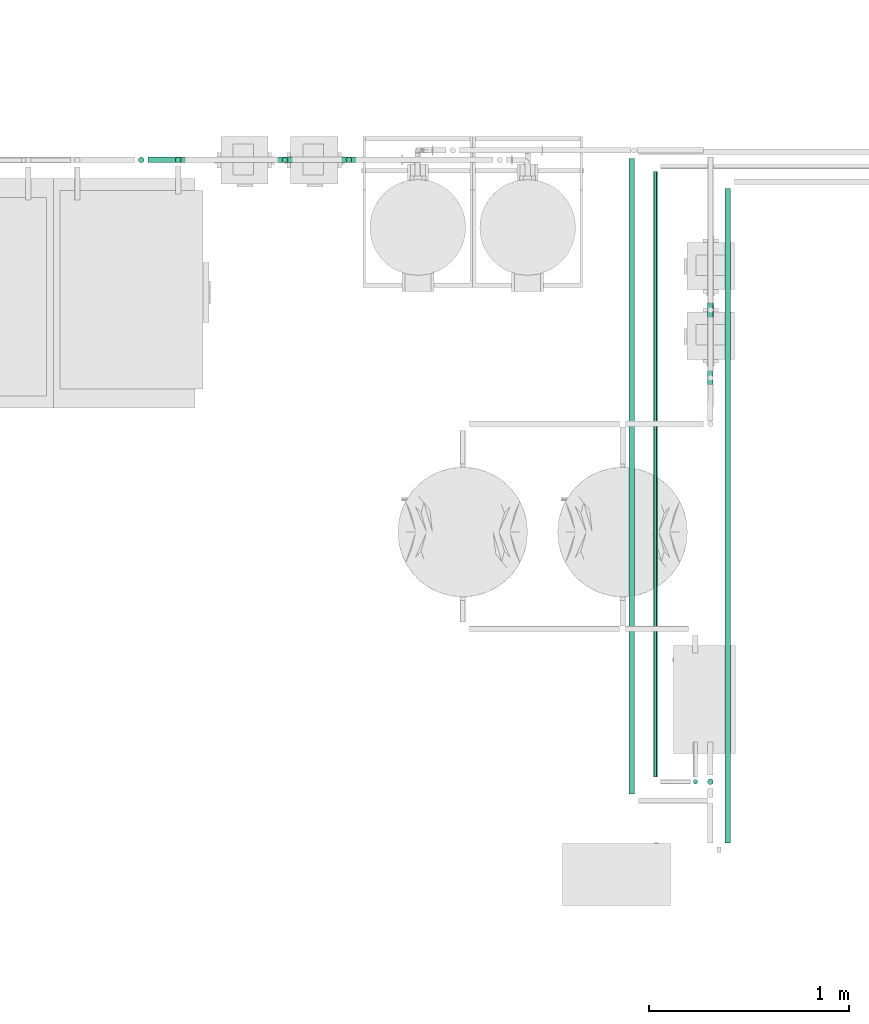
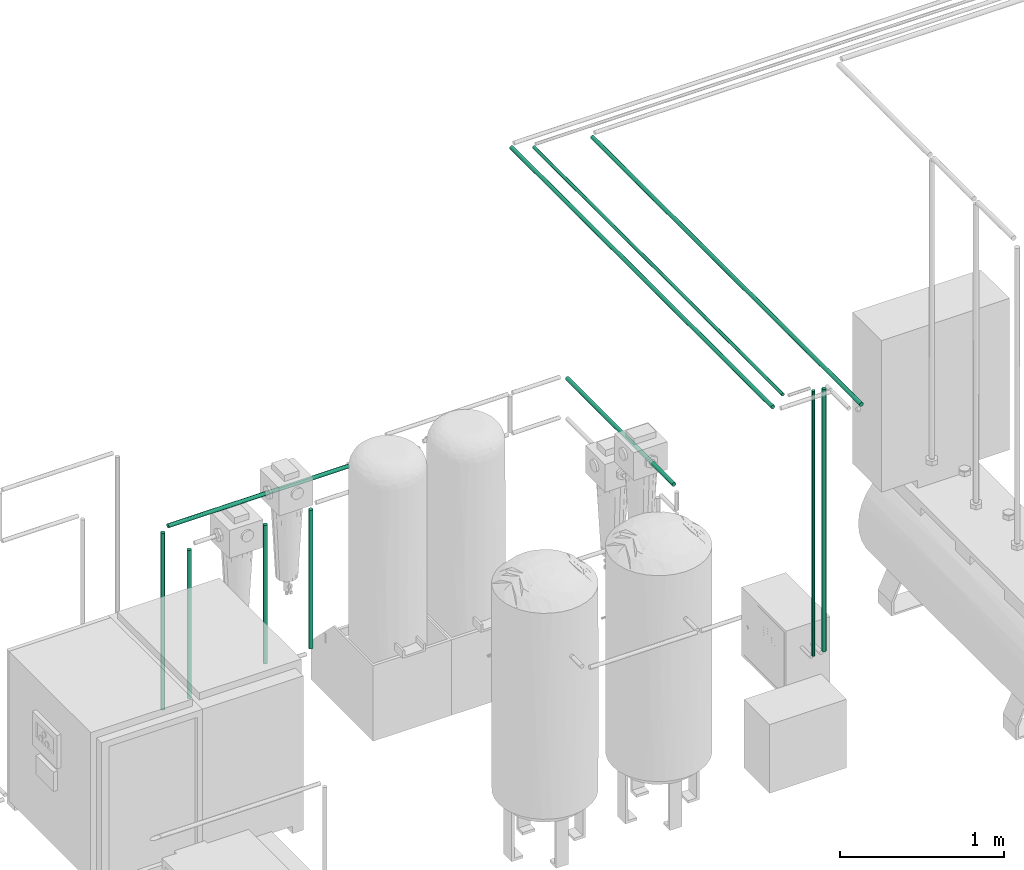
# One storey, part 42 of 331: 11 flow segments.
"""IFC2X3 building model written with IfcOpenShell, lengths in millimetres."""

from ifc_helpers import new_model, entity, si_unit, converted_unit, derived_unit, direction, frame, frame_2d, origin, origin_2d_with_axis, place, context, subcontext, project, spatial, circle, extrude, type_object, element, save


model = new_model("IFC2X3")

# Units and contexts
model_context = context("Model", 3, precision=0.01, world=origin(), true_north=direction((6.12303176911189e-17, 1.0)))
body_context = subcontext(model_context, "Body", "Model", "MODEL_VIEW")
ifc_project = project(units=[si_unit("LENGTHUNIT", "METRE", prefix="MILLI"), si_unit("AREAUNIT", "SQUARE_METRE"), si_unit("VOLUMEUNIT", "CUBIC_METRE"), converted_unit("PLANEANGLEUNIT", "DEGREE", entity("IfcRatioMeasure", 0.0174532925199433), si_unit("PLANEANGLEUNIT", "RADIAN"), dimensions=[0, 0, 0, 0, 0, 0, 0]), si_unit("MASSUNIT", "GRAM", prefix="KILO"), derived_unit("MASSDENSITYUNIT", [(si_unit("MASSUNIT", "GRAM", prefix="KILO"), 1), (si_unit("LENGTHUNIT", "METRE"), -3)]), derived_unit("MOMENTOFINERTIAUNIT", [(si_unit("LENGTHUNIT", "METRE"), 4)]), si_unit("TIMEUNIT", "SECOND"), si_unit("FREQUENCYUNIT", "HERTZ"), si_unit("THERMODYNAMICTEMPERATUREUNIT", "DEGREE_CELSIUS"), derived_unit("THERMALTRANSMITTANCEUNIT", [(si_unit("MASSUNIT", "GRAM", prefix="KILO"), 1), (si_unit("THERMODYNAMICTEMPERATUREUNIT", "KELVIN"), -1), (si_unit("TIMEUNIT", "SECOND"), -3)]), derived_unit("VOLUMETRICFLOWRATEUNIT", [(si_unit("LENGTHUNIT", "METRE"), 3), (si_unit("TIMEUNIT", "SECOND"), -1)]), derived_unit("MASSFLOWRATEUNIT", [(si_unit("MASSUNIT", "GRAM", prefix="KILO"), 1), (si_unit("TIMEUNIT", "SECOND"), -1)]), derived_unit("ROTATIONALFREQUENCYUNIT", [(si_unit("TIMEUNIT", "SECOND"), -1)]), si_unit("ELECTRICCURRENTUNIT", "AMPERE"), si_unit("ELECTRICVOLTAGEUNIT", "VOLT"), si_unit("POWERUNIT", "WATT"), si_unit("FORCEUNIT", "NEWTON", prefix="KILO"), si_unit("ILLUMINANCEUNIT", "LUX"), si_unit("LUMINOUSFLUXUNIT", "LUMEN"), si_unit("LUMINOUSINTENSITYUNIT", "CANDELA"), derived_unit("USERDEFINED", [(si_unit("MASSUNIT", "GRAM", prefix="KILO"), -1), (si_unit("LENGTHUNIT", "METRE"), -2), (si_unit("TIMEUNIT", "SECOND"), 3), (si_unit("LUMINOUSFLUXUNIT", "LUMEN"), 1)]), derived_unit("LINEARVELOCITYUNIT", [(si_unit("LENGTHUNIT", "METRE"), 1), (si_unit("TIMEUNIT", "SECOND"), -1)]), si_unit("PRESSUREUNIT", "PASCAL"), derived_unit("USERDEFINED", [(si_unit("LENGTHUNIT", "METRE"), -2), (si_unit("MASSUNIT", "GRAM", prefix="KILO"), 1), (si_unit("TIMEUNIT", "SECOND"), -2)]), derived_unit("LINEARFORCEUNIT", [(si_unit("MASSUNIT", "GRAM", prefix="KILO"), 1), (si_unit("LENGTHUNIT", "METRE"), 1), (si_unit("TIMEUNIT", "SECOND"), -2), (si_unit("LENGTHUNIT", "METRE"), -1)]), derived_unit("PLANARFORCEUNIT", [(si_unit("MASSUNIT", "GRAM", prefix="KILO"), 1), (si_unit("LENGTHUNIT", "METRE"), 1), (si_unit("TIMEUNIT", "SECOND"), -2), (si_unit("LENGTHUNIT", "METRE"), -2)])], contexts=[model_context])

# Site, building, storey
site_placement = place(None, frame((0.0, -0.00077364408347762, 0.0)))
site = spatial("IfcSite", under=ifc_project, at=site_placement, CompositionType="ELEMENT")
building_placement = place(site_placement, origin())
building = spatial("IfcBuilding", under=site, at=building_placement, CompositionType="ELEMENT")
storey_placement = place(building_placement, origin())
storey = spatial("IfcBuildingStorey", under=building, at=storey_placement, CompositionType="ELEMENT", Elevation=0.0)

# Flow segments
pipe_segment_type = type_object("IfcPipeSegmentType", PredefinedType="NOTDEFINED")
flow_segment_1_placement = place(storey_placement, frame((55259.7935041802, -3861.13012235031, 2834.40472776411)))
element("IfcFlowSegment", 1, at=flow_segment_1_placement, inside=storey, type_object=pipe_segment_type, context=body_context, shape_type="SweptSolid", body=[
    extrude(circle(Radius=14.0, at=origin_2d_with_axis()), frame((15.5952722359127, 0.0, 15.595272235916), z_axis=(0.0, 1.0, 0.0), x_axis=(-1.0, 0.0, 0.0)), (0.0, 0.0, 1.0), 3182.00000000001),
])
flow_segment_2_placement = place(storey_placement, frame((55382.4083446482, -3776.13012235021, 2837.40472776406)))
element("IfcFlowSegment", 2, at=flow_segment_2_placement, inside=storey, type_object=pipe_segment_type, context=body_context, shape_type="SweptSolid", body=[
    extrude(circle(Radius=11.0, at=frame_2d((8.66293703438714e-12, 0.0), x_axis=(1.0, 0.0))), frame((12.5952722359134, 0.0, 12.5952722359161), z_axis=(0.0, 1.0, 0.0), x_axis=(-1.0, 0.0, 0.0)), (0.0, 0.0, 1.0), 3032.00000000001),
])
flow_segment_3_placement = place(storey_placement, frame((52989.513262723, -702.470373934416, -438.473902728034)))
element("IfcFlowSegment", 3, at=flow_segment_3_placement, inside=storey, type_object=pipe_segment_type, context=body_context, shape_type="SweptSolid", body=[
    extrude(circle(Radius=14.0, at=origin_2d_with_axis()), frame((15.5952722359127, 15.5952722359161, 0.0)), (0.0, 0.0, 1.0), 1102.0),
])
flow_segment_4_placement = place(building_placement, frame((52804.5132627228, -702.470373934386, -458.473902728044)))
element("IfcFlowSegment", 4, at=flow_segment_4_placement, inside=storey, type_object=pipe_segment_type, context=body_context, shape_type="SweptSolid", body=[
    extrude(circle(Radius=14.0, at=origin_2d_with_axis()), frame((15.5952722359127, 15.5952722359161, 0.0), z_axis=(0.0, 0.0, 1.0), x_axis=(-1.0, 0.0, 0.0)), (0.0, 0.0, 1.0), 1314.47390272806),
])
flow_segment_5_placement = place(building_placement, frame((52854.1085349587, -702.470373934388, 874.404727764108)))
element("IfcFlowSegment", 5, at=flow_segment_5_placement, inside=storey, type_object=pipe_segment_type, context=body_context, shape_type="SweptSolid", body=[
    extrude(circle(Radius=14.0, at=frame_2d((1.35358391162299e-13, -1.27895354719979e-42), x_axis=(1.0, 0.0))), frame((0.0, 15.5952722359162, 15.5952722359161), z_axis=(1.0, 0.0, 0.0), x_axis=(0.0, -1.0, 0.0)), (0.0, 0.0, 1.0), 1270.36494850836),
])
flow_segment_6_placement = place(storey_placement, frame((53524.513262723, -702.470373934416, -368.473902728038)))
element("IfcFlowSegment", 6, at=flow_segment_6_placement, inside=storey, type_object=pipe_segment_type, context=body_context, shape_type="SweptSolid", body=[
    extrude(circle(Radius=14.0, at=origin_2d_with_axis()), frame((15.5952722359127, 15.5952722359161, 0.0)), (0.0, 0.0, 1.0), 1032.00000000001),
])
flow_segment_7_placement = place(storey_placement, frame((53844.513262723, -702.470373934416, -368.473902728038)))
element("IfcFlowSegment", 7, at=flow_segment_7_placement, inside=storey, type_object=pipe_segment_type, context=body_context, shape_type="SweptSolid", body=[
    extrude(circle(Radius=14.0, at=origin_2d_with_axis()), frame((15.5952722359127, 15.5952722359161, 0.0)), (0.0, 0.0, 1.0), 1031.99999999999),
])
flow_segment_8_placement = place(storey_placement, frame((55654.5240912248, -1974.35010090697, 976.915612714423)))
element("IfcFlowSegment", 8, at=flow_segment_8_placement, inside=storey, type_object=pipe_segment_type, context=body_context, shape_type="SweptSolid", body=[
    extrude(circle(Radius=14.0, at=frame_2d((-8.62136756965182e-17, 8.3975347766044e-28), x_axis=(1.0, 0.0))), frame((15.5952715259764, 0.00445850253297806, 15.5952722359161), z_axis=(0.000318464466651148, 0.999999949290191, 0.0), x_axis=(0.999999949290191, -0.000318464466651148, 0.0)), (0.0, 0.0, 1.0), 1301.2049816908),
])
flow_segment_9_placement = place(storey_placement, frame((55740.7632627227, -4106.13012235032, 2834.40472776406)))
element("IfcFlowSegment", 9, at=flow_segment_9_placement, inside=storey, type_object=pipe_segment_type, context=body_context, shape_type="SweptSolid", body=[
    extrude(circle(Radius=14.0, at=origin_2d_with_axis()), frame((15.5952722361553, 0.0, 15.595272235916), z_axis=(0.0, 1.0, 0.0), x_axis=(1.0, 0.0, 0.0)), (0.0, 0.0, 1.0), 3277.00000000015),
])
flow_segment_10_placement = place(storey_placement, frame((55582.4083446482, -3812.72539458613, 854.624999999974)))
element("IfcFlowSegment", 10, at=flow_segment_10_placement, inside=storey, type_object=pipe_segment_type, context=body_context, shape_type="SweptSolid", body=[
    extrude(circle(Radius=11.0, at=frame_2d((0.0, 5.41433564649196e-13), x_axis=(1.0, 0.0))), frame((12.5952722359134, 12.5952722359156, 0.0)), (0.0, 0.0, 1.0), 1971.37500000001),
])
flow_segment_11_placement = place(storey_placement, frame((55654.513262723, -3815.72539458611, 864.0)))
element("IfcFlowSegment", 11, at=flow_segment_11_placement, inside=storey, type_object=pipe_segment_type, context=body_context, shape_type="SweptSolid", body=[
    extrude(circle(Radius=14.0, at=origin_2d_with_axis()), frame((15.5952722359127, 15.595272235916, 0.0)), (0.0, 0.0, 1.0), 1952.00000000003),
])

save(model, "model.ifc")
